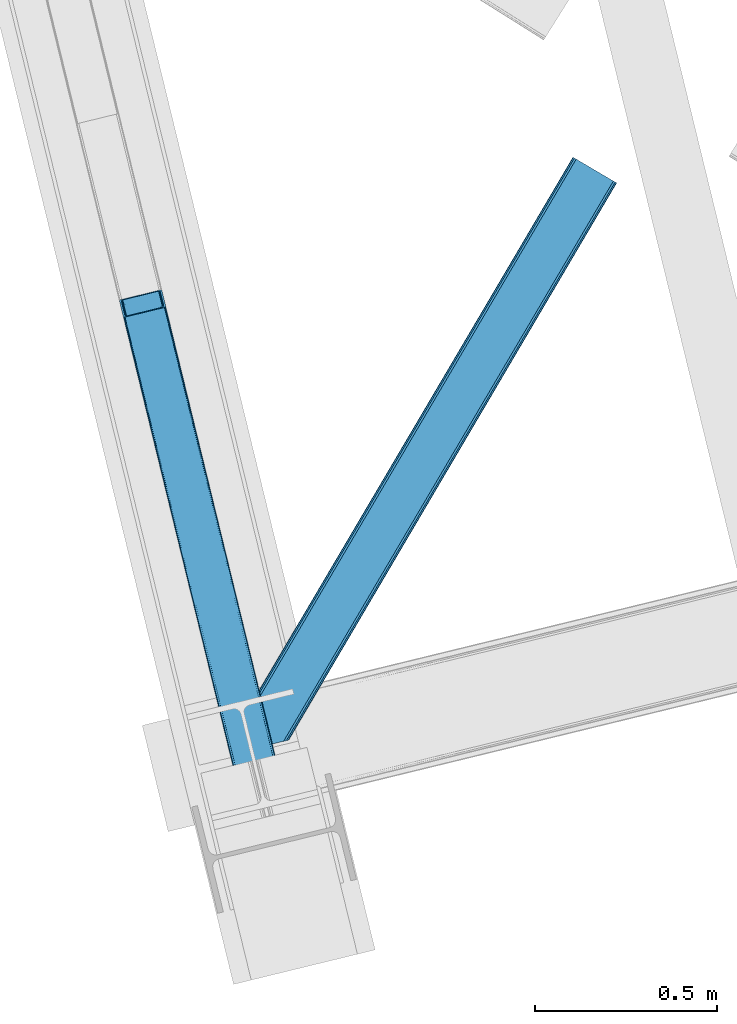
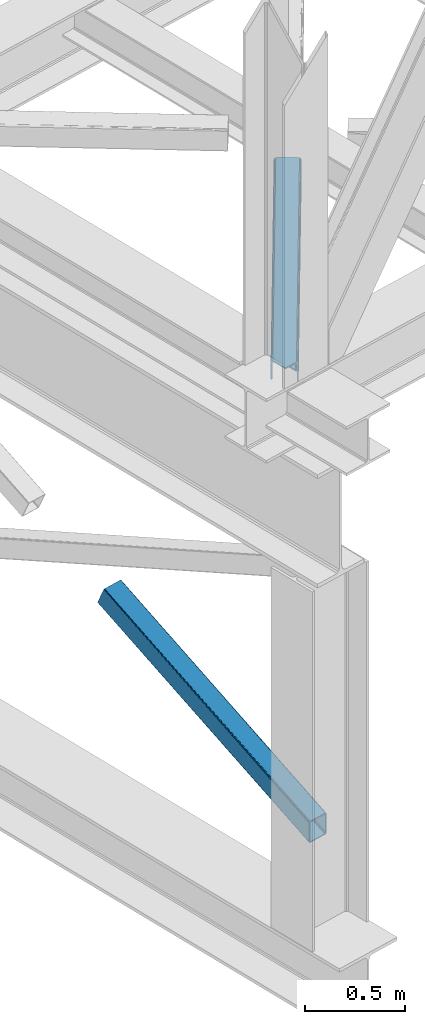
# One storey, part 22 of 93: 2 members.
"""IFC4 building model written with IfcOpenShell, lengths in millimetres."""

from ifc_helpers import new_model, entity, si_unit, converted_unit, derived_unit, direction, frame, origin, place, context, subcontext, project, spatial, triangles, type_object, element, save


model = new_model("IFC4")

# Units and contexts
model_context = context("Model", 3, precision=0.01, world=origin(), true_north=direction((6.12303176911189e-17, 1.0)))
plan_context = context("Plan", 3, precision=0.01, world=origin(), true_north=direction((6.12303176911189e-17, 1.0)))
body_context = subcontext(model_context, "Body", "Model", "MODEL_VIEW")
ifc_project = project(units=[si_unit("LENGTHUNIT", "METRE", prefix="MILLI"), si_unit("AREAUNIT", "SQUARE_METRE"), si_unit("VOLUMEUNIT", "CUBIC_METRE"), converted_unit("PLANEANGLEUNIT", "DEGREE", entity("IfcRatioMeasure", 0.0174532925199433), si_unit("PLANEANGLEUNIT", "RADIAN"), dimensions=[0, 0, 0, 0, 0, 0, 0]), si_unit("MASSUNIT", "GRAM", prefix="KILO"), derived_unit("MASSDENSITYUNIT", [(si_unit("MASSUNIT", "GRAM", prefix="KILO"), 1), (si_unit("LENGTHUNIT", "METRE"), -3)]), derived_unit("MOMENTOFINERTIAUNIT", [(si_unit("LENGTHUNIT", "METRE"), 4)]), si_unit("TIMEUNIT", "SECOND"), si_unit("FREQUENCYUNIT", "HERTZ"), si_unit("THERMODYNAMICTEMPERATUREUNIT", "DEGREE_CELSIUS"), derived_unit("THERMALTRANSMITTANCEUNIT", [(si_unit("MASSUNIT", "GRAM", prefix="KILO"), 1), (si_unit("THERMODYNAMICTEMPERATUREUNIT", "KELVIN"), -1), (si_unit("TIMEUNIT", "SECOND"), -3)]), derived_unit("VOLUMETRICFLOWRATEUNIT", [(si_unit("LENGTHUNIT", "METRE"), 3), (si_unit("TIMEUNIT", "SECOND"), -1)]), derived_unit("MASSFLOWRATEUNIT", [(si_unit("MASSUNIT", "GRAM", prefix="KILO"), 1), (si_unit("TIMEUNIT", "SECOND"), -1)]), derived_unit("ROTATIONALFREQUENCYUNIT", [(si_unit("TIMEUNIT", "SECOND"), -1)]), si_unit("ELECTRICCURRENTUNIT", "AMPERE"), si_unit("ELECTRICVOLTAGEUNIT", "VOLT"), si_unit("POWERUNIT", "WATT"), si_unit("FORCEUNIT", "NEWTON", prefix="KILO"), si_unit("ILLUMINANCEUNIT", "LUX"), si_unit("LUMINOUSFLUXUNIT", "LUMEN"), si_unit("LUMINOUSINTENSITYUNIT", "CANDELA"), derived_unit("USERDEFINED", [(si_unit("MASSUNIT", "GRAM", prefix="KILO"), -1), (si_unit("LENGTHUNIT", "METRE"), -2), (si_unit("TIMEUNIT", "SECOND"), 3), (si_unit("LUMINOUSFLUXUNIT", "LUMEN"), 1)]), derived_unit("LINEARVELOCITYUNIT", [(si_unit("LENGTHUNIT", "METRE"), 1), (si_unit("TIMEUNIT", "SECOND"), -1)]), si_unit("PRESSUREUNIT", "PASCAL"), derived_unit("USERDEFINED", [(si_unit("LENGTHUNIT", "METRE"), -2), (si_unit("MASSUNIT", "GRAM", prefix="KILO"), 1), (si_unit("TIMEUNIT", "SECOND"), -2)]), derived_unit("LINEARFORCEUNIT", [(si_unit("MASSUNIT", "GRAM", prefix="KILO"), 1), (si_unit("LENGTHUNIT", "METRE"), 1), (si_unit("TIMEUNIT", "SECOND"), -2), (si_unit("LENGTHUNIT", "METRE"), -1)]), derived_unit("PLANARFORCEUNIT", [(si_unit("MASSUNIT", "GRAM", prefix="KILO"), 1), (si_unit("LENGTHUNIT", "METRE"), 1), (si_unit("TIMEUNIT", "SECOND"), -2), (si_unit("LENGTHUNIT", "METRE"), -2)])], contexts=[model_context, plan_context])

# Site, building, storey
site_placement = place(None, origin())
site = spatial("IfcSite", under=ifc_project, at=site_placement, CompositionType="ELEMENT")
building_placement = place(site_placement, origin())
building = spatial("IfcBuilding", under=site, at=building_placement, CompositionType="ELEMENT")
storey_placement = place(building_placement, frame((0.0, 0.0, 15900.0)))
storey = spatial("IfcBuildingStorey", under=building, at=storey_placement, CompositionType="ELEMENT", Elevation=15900.0)

# Members
member_type_1 = type_object("IfcMemberType", PredefinedType="BRACE")
member_1_placement = place(storey_placement, frame((-60640.9590087891, 2666.95552597046, 911.279672241211)))
element("IfcMember", 1, at=member_1_placement, inside=storey, type_object=member_type_1, ObjectType="Steel Vertical Brace", PredefinedType="BRACE", context=body_context, shape_type="Tessellation", body=[
    triangles([(109.100317382814, 1516.67748184204, 692.224026489257), (472.282800292975, 26.7614479064941, 0.0), (6.11590576171875, 1491.57378158569, 692.224026489257), (369.298388671879, 1.65774765014658, 0.0), (115.806884765625, 1516.48156356812, 696.163320922849), (116.583581542975, 1515.53714447022, 698.605032348631), (479.087036132813, 28.4191955566407, 7.68092651366896), (114.109313964844, 1517.03007659912, 694.092517089841), (478.087097167969, 28.1761871337894, 4.96481323242188), (111.755969238286, 1517.09867706299, 692.710043334959), (477.091809082034, 27.9334693908695, 2.24986267089844), (474.687304687504, 27.3474586486818, 1.12551269531104), (126.913183593751, 1473.16763763428, 795.217739868163), (479.087036132813, 28.4191955566407, 123.979641723632), (123.345959472659, 1469.55913696289, 801.112728881835), (120.792626953131, 1468.71180496216, 801.59758300781), (472.282800292975, 26.7614479064941, 131.659405517577), (125.40164794922, 1470.70354385376, 799.729092407226), (474.687304687504, 27.3474586486818, 130.53505554199), (126.657385253908, 1471.97061767578, 797.659451293945), (477.091809082034, 27.9334693908695, 129.409542846679), (478.087097167969, 28.1761871337894, 126.694592285156), (17.8082153320356, 1443.60810470581, 801.59758300781), (369.298388671879, 1.65774765014658, 131.659405517577), (10.324951171875, 1444.74844207764, 795.217739868163), (362.498803710943, 0.0, 123.979641723632), (363.494091796878, 0.242717742919922, 126.694592285156), (11.1062988281265, 1443.8037322998, 797.659451293945), (364.489379882813, 0.485435485839844, 129.409542846679), (12.7992187500058, 1443.25550994873, 799.729092407226), (366.89388427735, 1.07173690795935, 130.53505554199), (15.152563476564, 1443.18661880493, 801.112728881835), (0.0, 1487.11794891357, 698.605032348631), (362.498803710943, 0.0, 7.68092651366896), (366.89388427735, 1.07173690795935, 1.12551269531104), (3.56722412109957, 1490.72644958496, 692.710043334959), (364.489379882813, 0.485435485839844, 2.24986267089844), (1.50688476562937, 1489.58204269409, 694.092517089841), (363.494091796878, 0.242717742919922, 4.96481323242188), (0.25579833984375, 1488.31496887207, 696.163320922849), (112.2117553711, 1512.35448989868, 703.161730957028), (111.43505859375, 1513.29890899658, 700.720019531247), (109.737487792969, 1513.84742202759, 698.650378417966), (104.728491210939, 1513.49453659058, 696.781887817382), (107.384143066411, 1513.91602249146, 697.266741943356), (120.057788085942, 1471.51802902222, 795.172393798828), (121.569323730473, 1473.98212280273, 790.661041259766), (121.30887451172, 1472.78510284424, 793.102752685547), (117.997448730472, 1470.37362213135, 796.55486755371), (115.448767089845, 1469.52599945068, 797.040884399412), (6.85074462890771, 1488.76755752563, 698.650378417966), (5.59965820312937, 1487.50048370361, 700.720019531247), (11.4597656250044, 1490.75929641724, 696.781887817382), (8.91108398437791, 1489.9119644165, 697.266741943356), (5.34385986328562, 1486.30346374512, 703.161730957028), (17.1710449218808, 1446.43816452026, 795.172393798828), (19.524389648439, 1446.3695640564, 796.55486755371), (15.4734741210996, 1446.98667755127, 793.102752685547), (22.1800415039106, 1446.79075927734, 797.040884399412), (14.69677734375, 1447.93109664917, 790.661041259766), (371.754052734381, 2.25567626953125, 125.048181152342), (374.158557128911, 2.84197769165075, 126.173693847653), (369.349548339844, 1.66966552734402, 123.923831176755), (367.354321289065, 1.18423004150418, 118.492767333984), (368.354260253909, 1.4269477844241, 121.208880615231), (472.236291503912, 26.7495300292971, 123.923831176755), (467.427282714845, 25.5772178649904, 126.173693847653), (469.831787109375, 26.1632286071781, 125.048181152342), (473.231579589847, 26.9922477722171, 121.208880615231), (474.226867675781, 27.234965515137, 118.492767333984), (369.349548339844, 1.66966552734402, 7.73557434081886), (371.754052734381, 2.25567626953125, 6.61122436523146), (367.354321289065, 1.18423004150418, 13.166638183593), (368.354260253909, 1.4269477844241, 10.4505249023423), (374.158557128911, 2.84197769165075, 5.48571166992042), (472.236291503912, 26.7495300292971, 7.73557434081886), (473.231579589847, 26.9922477722171, 10.4505249023423), (469.831787109375, 26.1632286071781, 6.61122436523146), (474.226867675781, 27.234965515137, 13.166638183593), (467.427282714845, 25.5772178649904, 5.48571166992042)], [[1, 2, 3], [4, 3, 2], [5, 6, 7], [8, 5, 9], [10, 8, 11], [1, 10, 12], [12, 2, 1], [11, 12, 10], [9, 11, 8], [7, 9, 5], [6, 13, 14], [14, 7, 6], [15, 16, 17], [18, 15, 19], [20, 18, 21], [13, 20, 22], [22, 14, 13], [21, 22, 20], [19, 21, 18], [17, 19, 15], [17, 16, 23], [23, 24, 17], [25, 26, 27], [28, 27, 29], [30, 29, 31], [32, 31, 24], [24, 23, 32], [31, 32, 30], [29, 30, 28], [27, 28, 25], [25, 33, 26], [34, 26, 33], [3, 4, 35], [36, 35, 37], [38, 37, 39], [40, 39, 34], [34, 33, 40], [39, 40, 38], [37, 38, 36], [35, 36, 3], [41, 6, 42], [43, 5, 8], [8, 10, 43], [6, 41, 13], [6, 5, 43], [43, 42, 6], [44, 1, 3], [1, 45, 43], [44, 45, 1], [1, 43, 10], [18, 46, 15], [47, 13, 41], [46, 20, 13], [48, 13, 47], [20, 46, 18], [46, 16, 15], [13, 48, 46], [46, 49, 16], [16, 50, 23], [50, 16, 49], [51, 33, 52], [3, 53, 44], [54, 3, 51], [3, 54, 53], [51, 3, 36], [55, 52, 33], [36, 38, 51], [40, 51, 38], [55, 33, 25], [40, 33, 51], [56, 32, 23], [57, 56, 23], [58, 25, 56], [59, 23, 50], [23, 59, 57], [30, 32, 56], [25, 60, 55], [28, 56, 25], [60, 25, 58], [56, 28, 30], [61, 62, 24], [27, 63, 31], [27, 31, 29], [24, 62, 17], [24, 31, 61], [63, 61, 31], [64, 26, 34], [26, 65, 63], [64, 65, 26], [26, 63, 27], [19, 66, 22], [67, 17, 62], [68, 19, 17], [68, 17, 67], [22, 21, 19], [66, 14, 22], [19, 68, 66], [66, 69, 14], [14, 70, 7], [70, 14, 69], [71, 35, 72], [34, 73, 64], [74, 34, 71], [34, 74, 73], [71, 34, 39], [72, 4, 75], [71, 39, 35], [35, 39, 37], [75, 4, 2], [35, 4, 72], [76, 9, 7], [77, 76, 7], [78, 12, 76], [79, 7, 70], [7, 79, 77], [12, 9, 76], [2, 80, 75], [12, 78, 2], [80, 2, 78], [11, 9, 12], [80, 44, 75], [53, 75, 44], [44, 80, 78], [45, 78, 76], [43, 76, 77], [42, 77, 79], [79, 41, 42], [77, 42, 43], [76, 43, 45], [78, 45, 44], [47, 41, 70], [79, 70, 41], [47, 70, 69], [48, 69, 66], [46, 66, 68], [49, 68, 67], [67, 50, 49], [68, 49, 46], [66, 46, 48], [69, 48, 47], [50, 67, 59], [62, 59, 67], [57, 59, 62], [56, 57, 61], [58, 56, 63], [60, 58, 65], [65, 64, 60], [63, 65, 58], [61, 63, 56], [62, 61, 57], [55, 60, 64], [64, 73, 55], [52, 55, 73], [51, 52, 74], [54, 51, 71], [53, 54, 72], [72, 75, 53], [71, 72, 54], [74, 71, 51], [73, 74, 52]]),
])
member_type_2 = type_object("IfcMemberType", PredefinedType="BRACE")
member_2_placement = place(storey_placement, frame((-60290.0501953125, 2927.61955718994, 3511.0000579834)))
element("IfcMember", 2, at=member_2_placement, inside=storey, type_object=member_type_2, ObjectType="Steel Horizontal Brace", PredefinedType="BRACE", context=body_context, shape_type="Tessellation", body=[
    triangles([(154.446386718751, 124.708666992187, 0.0), (118.769494628912, 271.071535491943, 0.0), (998.971582031256, 1559.19843292236, 0.0), (908.488732910162, 1612.46872787476, 0.0), (1004.74332275391, 1555.80096588135, 1.33247680664135), (156.720666503912, 115.373480987549, 1.33247680664135), (1009.63139648438, 1552.92061843872, 5.12526855468968), (158.650781250006, 107.459719848633, 5.12526855468968), (1012.90096435547, 1550.99602661133, 10.8028289794929), (159.939074707036, 102.171670532226, 10.8028289794929), (1014.04973144532, 1550.32019577026, 17.5000946044929), (160.39486083985, 100.314807128906, 17.5000946044929), (902.716992187503, 1615.86619491577, 1.33247680664135), (116.495214843751, 280.40643081665, 1.33247680664135), (114.574401855469, 288.275717926025, 5.17061462402489), (897.824267578129, 1618.74683303833, 5.12526855468968), (114.495336914064, 288.596628570557, 5.32641906738354), (894.554699707034, 1620.67142486572, 10.8028289794929), (109.625866699222, 287.408910369873, 10.8028289794929), (893.405932617192, 1621.34696502686, 17.5000946044929), (107.821325683595, 286.969111633301, 17.5000946044929), (113.523303222661, 288.35972442627, 18.5197998046897), (114.495336914064, 288.596628570557, 17.5198608398459), (114.420922851568, 288.578606414795, 17.9023956298843), (114.211633300787, 288.527156066894, 18.2279571533218), (113.895373535161, 288.450416564941, 18.4442230224631), (107.821325683595, 286.969111633301, 18.5197998046897), (115.695263671878, 283.683556365967, 17.5198608398459), (115.625500488284, 283.800409698486, 17.8035644531265), (115.565039062501, 283.740238952636, 17.8570495605491), (115.323193359378, 283.495486450195, 18.0768035888686), (115.067395019534, 283.239106750488, 18.3081848144539), (114.830200195313, 283.003074645996, 18.5197998046897), (0.0, 103.824476623535, 18.5197998046897), (2.73471679687646, 92.5987083435057, 18.5197998046897), (893.405932617192, 1621.34696502686, 122.500662231447), (0.0, 103.824476623535, 122.500662231447), (908.488732910162, 1612.46872787476, 139.999594116212), (902.716992187503, 1615.86619491577, 138.667117309571), (3.66954345703562, 88.7658027648927, 138.667117309571), (5.94382324218896, 79.430616760254, 139.999594116212), (897.824267578129, 1618.74683303833, 134.874325561526), (1.73942871094187, 96.6798545837401, 134.874325561526), (894.554699707034, 1620.67142486572, 129.197927856447), (0.451135253912071, 101.967613220215, 129.197927856447), (899.438122558597, 1617.795728302, 24.4996673583992), (2.37659912109666, 94.0669326782227, 24.4996673583992), (900.586889648439, 1617.11989746094, 17.8035644531265), (903.856457519534, 1615.19530563355, 12.1260040283232), (914.516271972658, 1608.9174911499, 6.99957275390625), (908.749182128908, 1612.31495819092, 8.3320495605476), (118.871813964848, 270.648886871338, 8.3320495605476), (121.146093750001, 261.313991546631, 6.99957275390625), (116.941699218754, 278.562938690186, 12.1260040283232), (152.069787597662, 134.4662109375, 6.99957275390625), (992.939392089844, 1562.74996032715, 6.99957275390625), (156.274182128909, 117.217263793945, 12.1260040283232), (154.344067382815, 125.131024932861, 8.3320495605476), (157.520617675786, 112.096646118164, 17.5198608398459), (160.39486083985, 100.314807128906, 17.5198608398459), (899.438122558597, 1617.795728302, 115.501089477541), (2.37659912109666, 94.0669326782227, 115.501089477541), (900.586889648439, 1617.11989746094, 122.196029663086), (2.82773437500146, 92.2100692749023, 122.196029663086), (903.856457519534, 1615.19530563355, 127.87475280762), (4.12067871094041, 86.9223106384275, 127.87475280762), (908.749182128908, 1612.31495819092, 131.667544555665), (6.046142578125, 79.0082588195801, 131.667544555665), (914.516271972658, 1608.9174911499, 133.000021362306), (8.3250732421875, 69.6733634948728, 133.000021362306), (25.3054321289092, 0.0, 133.000021362306), (25.3054321289092, 0.0, 139.999594116212), (90.3619262695356, 15.8580436706543, 139.999594116212), (998.971582031256, 1559.19843292236, 139.999594116212), (1014.04973144532, 1550.32019577026, 122.500662231447), (1012.90096435547, 1550.99602661133, 129.197927856447), (114.0721069336, 21.6376327514649, 122.500662231447), (112.267565917973, 21.1975433349608, 129.197927856447), (1009.63139648438, 1552.92061843872, 134.874325561526), (107.128344726567, 19.9447128295897, 134.874325561526), (1004.74332275391, 1555.80096588135, 138.667117309571), (99.435791015625, 18.0698272705076, 138.667117309571), (159.664672851563, 99.0785453796384, 18.5197998046897), (114.0721069336, 21.6376327514649, 18.5197998046897), (103.161145019534, 18.9779113769532, 18.5197998046897), (156.929956054693, 110.304313659668, 18.5197998046897), (1008.01754150391, 1553.87143249512, 24.4996673583992), (1006.86877441406, 1554.54726333618, 17.8035644531265), (157.222961425781, 111.200479888916, 18.0198303222678), (1003.59920654297, 1556.47185516357, 12.1260040283232), (998.706481933594, 1559.3522026062, 8.3320495605476), (104.588964843751, 19.325855255127, 24.4996673583992), (1003.59920654297, 1556.47185516357, 127.87475280762), (1008.01754150391, 1553.87143249512, 115.501089477541), (1006.86877441406, 1554.54726333618, 122.196029663086), (992.939392089844, 1562.74996032715, 133.000021362306), (998.706481933594, 1559.3522026062, 131.667544555665), (102.784423828125, 18.8857658386228, 122.196029663086), (80.8787841796875, 13.5462661743163, 133.000021362306), (89.9526489257842, 15.7577590942383, 131.667544555665), (97.6452026367188, 17.6329353332517, 127.87475280762), (104.588964843751, 19.325855255127, 115.501089477541)], [[1, 2, 3], [4, 3, 2], [3, 5, 1], [6, 1, 5], [5, 7, 6], [8, 6, 7], [7, 9, 8], [10, 8, 9], [9, 11, 10], [12, 10, 11], [13, 14, 15], [16, 15, 17], [17, 18, 16], [17, 19, 18], [20, 18, 19], [19, 21, 20], [15, 16, 13], [13, 4, 14], [2, 14, 4], [22, 23, 24], [22, 25, 26], [27, 21, 22], [24, 25, 22], [23, 22, 21], [21, 19, 23], [17, 23, 19], [23, 28, 29], [29, 24, 23], [25, 24, 30], [26, 25, 31], [22, 26, 32], [32, 33, 22], [31, 32, 26], [30, 31, 25], [29, 30, 24], [34, 33, 35], [33, 34, 27], [22, 33, 27], [27, 20, 21], [36, 27, 37], [27, 36, 20], [27, 34, 37], [38, 39, 40], [40, 41, 38], [39, 42, 43], [43, 40, 39], [42, 44, 45], [45, 43, 42], [44, 36, 37], [37, 45, 44], [46, 47, 33], [33, 48, 46], [33, 31, 48], [47, 35, 33], [49, 48, 28], [50, 51, 52], [52, 53, 50], [51, 49, 54], [54, 52, 51], [28, 54, 49], [53, 55, 56], [56, 50, 53], [55, 2, 1], [54, 17, 14], [52, 14, 2], [52, 2, 53], [55, 53, 2], [17, 28, 23], [54, 28, 17], [52, 54, 14], [57, 58, 6], [58, 1, 6], [1, 58, 55], [8, 57, 6], [8, 59, 57], [10, 59, 8], [10, 60, 59], [46, 61, 47], [62, 47, 61], [61, 63, 62], [64, 62, 63], [63, 65, 64], [66, 64, 65], [65, 67, 66], [68, 66, 67], [67, 69, 68], [70, 68, 69], [66, 43, 64], [71, 72, 70], [72, 41, 70], [40, 68, 41], [66, 68, 40], [68, 70, 41], [66, 40, 43], [37, 34, 62], [45, 64, 43], [62, 64, 37], [64, 45, 37], [34, 47, 62], [34, 35, 47], [41, 73, 74], [73, 41, 72], [74, 38, 41], [75, 76, 77], [78, 77, 76], [76, 79, 78], [80, 78, 79], [79, 81, 80], [82, 80, 81], [81, 74, 82], [73, 82, 74], [60, 75, 77], [60, 11, 75], [77, 83, 60], [77, 84, 83], [84, 85, 83], [86, 83, 85], [87, 88, 59], [89, 86, 87], [88, 90, 57], [57, 59, 88], [90, 91, 58], [58, 57, 90], [91, 56, 55], [55, 58, 91], [87, 86, 92], [85, 92, 86], [9, 90, 88], [87, 75, 11], [9, 88, 11], [9, 7, 90], [88, 87, 11], [90, 7, 5], [56, 3, 4], [3, 91, 5], [91, 3, 56], [91, 90, 5], [76, 93, 79], [94, 75, 87], [75, 95, 76], [95, 75, 94], [76, 95, 93], [74, 96, 38], [81, 79, 93], [93, 97, 81], [97, 96, 74], [74, 81, 97], [49, 13, 16], [4, 50, 56], [4, 51, 50], [51, 4, 13], [49, 51, 13], [46, 20, 36], [18, 48, 49], [16, 18, 49], [48, 18, 20], [46, 48, 20], [39, 65, 42], [38, 96, 69], [69, 67, 38], [67, 65, 39], [39, 38, 67], [44, 42, 65], [36, 61, 46], [63, 36, 44], [36, 63, 61], [63, 44, 65], [98, 78, 80], [99, 73, 72], [72, 71, 99], [99, 100, 73], [100, 82, 73], [101, 82, 100], [80, 82, 101], [98, 77, 78], [102, 77, 98], [80, 101, 98], [84, 92, 85], [102, 84, 77], [92, 84, 102], [99, 70, 96], [99, 71, 70], [69, 96, 70], [96, 97, 100], [100, 99, 96], [97, 93, 101], [101, 100, 97], [93, 95, 98], [98, 101, 93], [95, 94, 102], [102, 98, 95], [94, 87, 102], [92, 102, 87]]),
])

save(model, "model.ifc")
